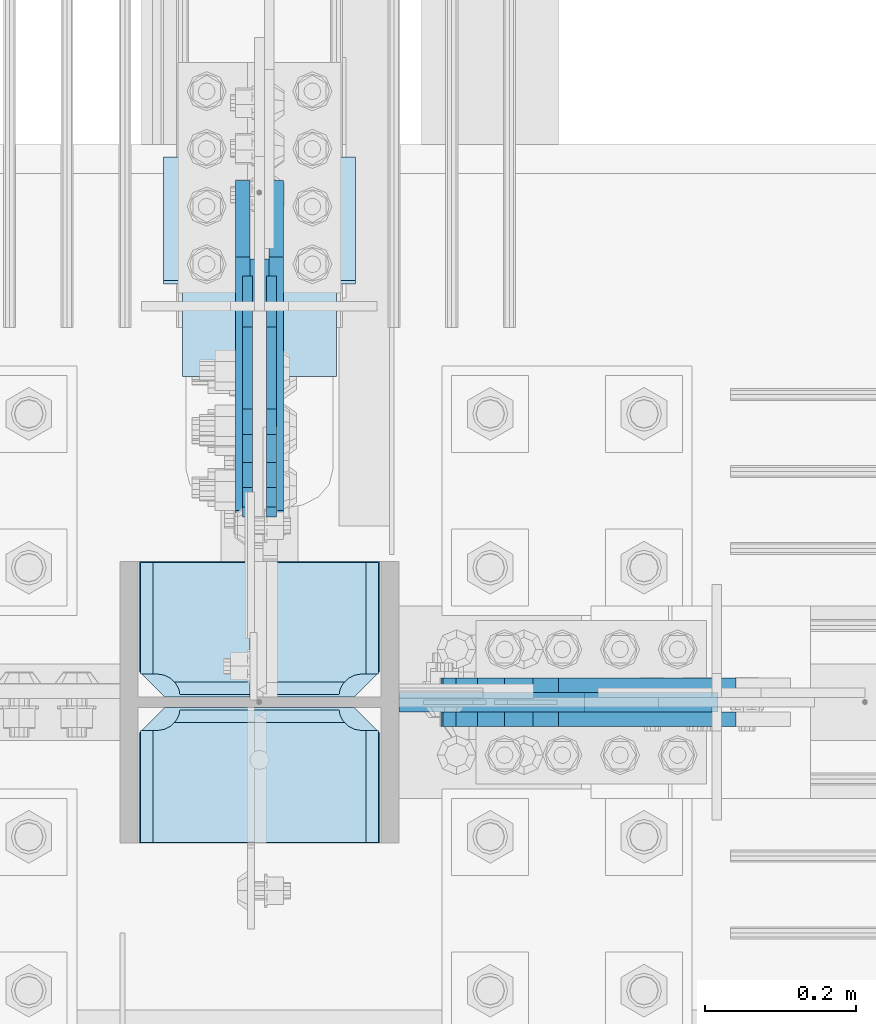
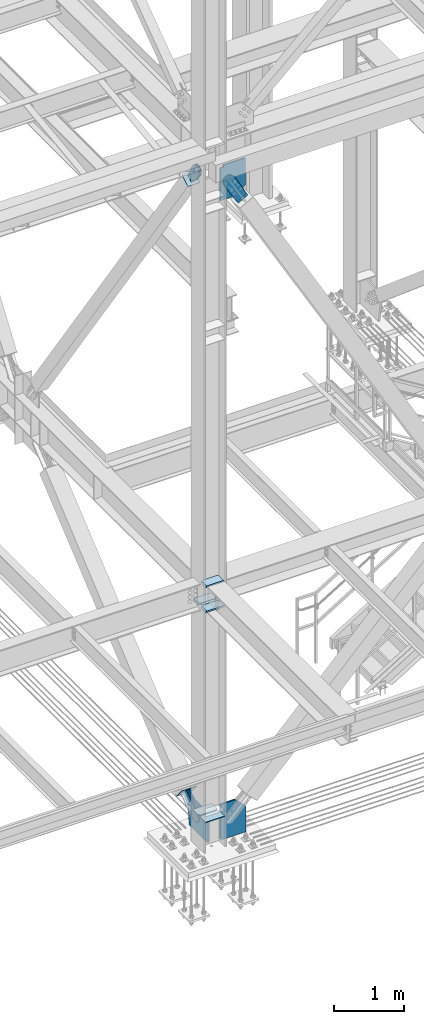
# One storey, part 3095 of 3843: 16 plates, 9 elements without a shape of their own.
"""IFC2X3 building model written with IfcOpenShell, lengths in millimetres."""

from ifc_helpers import new_model, si_unit, frame, origin_with_axes, place, context, subcontext, project, spatial, faceted_brep, material, type_object, element, aggregate, save


model = new_model("IFC2X3")

# Units and contexts
model_context = context("Model", 3, precision=1e-05, world=origin_with_axes())
body_context = subcontext(model_context, "Body", "Model", "MODEL_VIEW")
ifc_project = project(units=[si_unit("LENGTHUNIT", "METRE", prefix="MILLI"), si_unit("AREAUNIT", "SQUARE_METRE"), si_unit("VOLUMEUNIT", "CUBIC_METRE"), si_unit("MASSUNIT", "GRAM", prefix="KILO"), si_unit("TIMEUNIT", "SECOND"), si_unit("PLANEANGLEUNIT", "RADIAN"), si_unit("SOLIDANGLEUNIT", "STERADIAN"), si_unit("THERMODYNAMICTEMPERATUREUNIT", "DEGREE_CELSIUS"), si_unit("LUMINOUSINTENSITYUNIT", "LUMEN")], contexts=[model_context])

# Site, building, storey
site_placement = place(None, origin_with_axes())
site = spatial("IfcSite", under=ifc_project, at=site_placement, CompositionType="ELEMENT")
building_placement = place(site_placement, origin_with_axes())
building = spatial("IfcBuilding", under=site, at=building_placement, Name="Undefined", CompositionType="ELEMENT")
storey_placement = place(building_placement, origin_with_axes())
storey = spatial("IfcBuildingStorey", under=building, at=storey_placement, Name="Undefined", CompositionType="ELEMENT", Elevation=0.0)

# Assembly, plates
assembly_1_placement = place(storey_placement, origin_with_axes())
assembly_1 = element("IfcElementAssembly", 1, at=assembly_1_placement, inside=storey, Name="COLUMN", AssemblyPlace="NOTDEFINED", PredefinedType="RIGID_FRAME")
ifc_material_1 = material(Name="STEEL/A572-50")
plate_type_1 = type_object("IfcPlateType", PredefinedType="NOTDEFINED")
plate_1_placement = place(assembly_1_placement, frame((77171.55, 15005.84375, 30682.5348166373), z_axis=(0.0, 1.0, 0.0), x_axis=(-1.0, 0.0, 0.0)))
plate_1 = element("IfcPlate", 2, at=plate_1_placement, type_object=plate_type_1, material=ifc_material_1, Name="CB_COL", context=body_context, shape_type="Brep", body=[
    faceted_brep([(0.0, -6.34999999999854, 33.3375015258789), (0.0, -6.34999999999854, 178.59375), (0.0, 6.34999999999854, 178.59375), (0.0, 6.34999999999854, 33.3375015258789), (317.499999999985, -6.34999999999854, 178.59375), (317.499999999985, 6.34999999999854, 178.59375), (317.499999999985, -6.34999999999854, 33.3375015258789), (317.499999999985, 6.34999999999854, 33.3375015258789), (284.162498474107, -6.34999999999854, 0.0), (284.162498474107, 6.34999999999854, 0.0), (33.3375015258789, -6.34999999999854, 0.0), (33.3375015258789, 6.34999999999854, 0.0)], [[[0, 1, 2, 3]], [[1, 4, 5, 2]], [[4, 6, 7, 5]], [[6, 8, 9, 7]], [[8, 10, 11, 9]], [[10, 0, 3, 11]], [[5, 7, 9, 11, 3, 2]], [[10, 8, 6, 4, 1, 0]]]),
])
plate_2_placement = place(assembly_1_placement, frame((77171.55, 14991.55625, 30682.5348166373), z_axis=(0.0, -1.0, 0.0), x_axis=(-1.0, 0.0, 0.0)))
plate_2 = element("IfcPlate", 3, at=plate_2_placement, type_object=plate_type_1, material=ifc_material_1, Name="CB_COL", context=body_context, shape_type="Brep", body=[
    faceted_brep([(0.0, -6.34999999999854, 33.3375015258789), (0.0, -6.34999999999854, 178.59375), (0.0, 6.34999999999854, 178.59375), (0.0, 6.34999999999854, 33.3375015258789), (317.499999999985, -6.34999999999854, 178.59375), (317.499999999985, 6.34999999999854, 178.59375), (317.499999999985, -6.34999999999854, 33.3375015258789), (317.499999999985, 6.34999999999854, 33.3375015258789), (284.162498474107, -6.34999999999854, 0.0), (284.162498474107, 6.34999999999854, 0.0), (33.3375015258789, -6.34999999999854, 0.0), (33.3375015258789, 6.34999999999854, 0.0)], [[[0, 1, 2, 3]], [[1, 4, 5, 2]], [[4, 6, 7, 5]], [[6, 8, 9, 7]], [[8, 10, 11, 9]], [[10, 0, 3, 11]], [[5, 7, 9, 11, 3, 2]], [[10, 8, 6, 4, 1, 0]]]),
])
plate_type_2 = type_object("IfcPlateType", PredefinedType="NOTDEFINED")
plate_3_placement = place(assembly_1_placement, frame((77173.1375, 14991.55625, 34358.2625), z_axis=(-1.0, 0.0, 0.0), x_axis=(0.0, -1.0, 0.0)))
plate_3 = element("IfcPlate", 4, at=plate_3_placement, type_object=plate_type_2, material=ifc_material_1, Name="PLATE", context=body_context, shape_type="Brep", body=[
    faceted_brep([(17.7290728964945, 10.921700165738, 270.873024980028), (19.6722843348944, 14.2874999999985, 272.816236418425), (19.6722843348944, 14.2874999999985, 47.8587635815784), (17.7290728964945, 10.921700165738, 49.8019750199746), (9.32072521071495, -3.64224006636505, 54.0862421540805), (3.174499952318, -14.2874999999985, 55.0597086017369), (3.174499952318, -14.2874999999985, 265.615291398266), (9.32072521071677, -3.64224006636505, 266.588757845922), (177.799999999999, 14.2874999999985, 19.672284334898), (177.799999999999, -14.2874999999985, 3.17449995232164), (30.1625003814697, -14.2874999999985, 3.17449995232164), (30.1625003814697, 14.2874999999985, 19.672284334898), (30.1625003814697, 14.2874999999985, 301.001715665116), (30.1625003814697, -14.2874999999985, 317.499500047692), (177.800000000001, -14.2874999999985, 317.499500047692), (177.800000000001, 14.2874999999985, 301.001715665116), (9.32072521071677, -14.2874999999985, 266.588757845922), (17.7290728964945, -14.2874999999985, 270.873024980028), (24.4019754014498, -14.2874999999985, 277.545927484985), (24.4019754014498, 14.2874999999985, 277.545927484985), (28.6862425355521, -14.2874999999985, 285.954275170763), (28.6862425355521, 14.2874999999985, 285.954275170763), (30.1625003814697, -14.2874999999985, 295.275000381473), (30.1625003814697, 14.2874999999985, 295.275000381473), (30.1625003814697, -14.2874999999985, 25.3999996185303), (30.1625003814697, 14.2874999999985, 25.3999996185303), (28.6862425355503, -14.2874999999985, 34.7207248292398), (28.6862425355503, 14.2874999999985, 34.7207248292398), (24.401975401448, -14.2874999999985, 43.1290725150175), (24.401975401448, 14.2874999999985, 43.1290725150175), (17.7290728964945, -14.2874999999985, 49.8019750199746), (9.32072521071677, -14.2874999999985, 54.0862421540805)], [[[0, 1, 2, 3, 4, 5, 6, 7]], [[8, 9, 10, 11]], [[12, 13, 14, 15]], [[16, 7, 6]], [[16, 17, 0, 7]], [[17, 18, 19, 1, 0]], [[18, 20, 21, 19]], [[20, 22, 23, 21]], [[23, 22, 13, 12]], [[15, 14, 9, 8]], [[24, 25, 11, 10]], [[24, 26, 27, 25]], [[26, 28, 29, 27]], [[29, 28, 30, 3, 2]], [[30, 31, 4, 3]], [[31, 5, 4]], [[19, 21, 23, 12, 15, 8, 11, 25, 27, 29, 2, 1]], [[31, 30, 28, 26, 24, 10, 9, 14, 13, 22, 20, 18, 17, 16, 6, 5]]]),
])
plate_4_placement = place(assembly_1_placement, frame((77173.1375, 14991.55625, 34796.4125), z_axis=(-1.0, 0.0, 0.0), x_axis=(0.0, -1.0, 0.0)))
plate_4 = element("IfcPlate", 5, at=plate_4_placement, type_object=plate_type_2, material=ifc_material_1, Name="PLATE", context=body_context, shape_type="Brep", body=[
    faceted_brep([(17.7290728964945, 10.921700165738, 270.873024980028), (19.6722843348944, 14.2874999999985, 272.816236418425), (19.6722843348944, 14.2874999999985, 47.8587635815784), (17.7290728964945, 10.921700165738, 49.8019750199746), (9.32072521071495, -3.64224006636505, 54.0862421540805), (3.174499952318, -14.2874999999985, 55.0597086017369), (3.174499952318, -14.2874999999985, 265.615291398266), (9.32072521071677, -3.64224006636505, 266.588757845922), (177.799999999999, 14.2874999999985, 19.672284334898), (177.799999999999, -14.2874999999985, 3.17449995232164), (30.1625003814697, -14.2874999999985, 3.17449995232164), (30.1625003814697, 14.2874999999985, 19.672284334898), (30.1625003814697, 14.2874999999985, 301.001715665116), (30.1625003814697, -14.2874999999985, 317.499500047692), (177.800000000001, -14.2874999999985, 317.499500047692), (177.800000000001, 14.2874999999985, 301.001715665116), (9.32072521071677, -14.2874999999985, 266.588757845922), (17.7290728964945, -14.2874999999985, 270.873024980028), (24.4019754014498, -14.2874999999985, 277.545927484985), (24.4019754014498, 14.2874999999985, 277.545927484985), (28.6862425355521, -14.2874999999985, 285.954275170763), (28.6862425355521, 14.2874999999985, 285.954275170763), (30.1625003814697, -14.2874999999985, 295.275000381473), (30.1625003814697, 14.2874999999985, 295.275000381473), (30.1625003814697, -14.2874999999985, 25.3999996185303), (30.1625003814697, 14.2874999999985, 25.3999996185303), (28.6862425355503, -14.2874999999985, 34.7207248292398), (28.6862425355503, 14.2874999999985, 34.7207248292398), (24.401975401448, -14.2874999999985, 43.1290725150175), (24.401975401448, 14.2874999999985, 43.1290725150175), (17.7290728964945, -14.2874999999985, 49.8019750199746), (9.32072521071677, -14.2874999999985, 54.0862421540805)], [[[0, 1, 2, 3, 4, 5, 6, 7]], [[8, 9, 10, 11]], [[12, 13, 14, 15]], [[16, 7, 6]], [[16, 17, 0, 7]], [[17, 18, 19, 1, 0]], [[18, 20, 21, 19]], [[20, 22, 23, 21]], [[23, 22, 13, 12]], [[15, 14, 9, 8]], [[24, 25, 11, 10]], [[24, 26, 27, 25]], [[26, 28, 29, 27]], [[29, 28, 30, 3, 2]], [[30, 31, 4, 3]], [[31, 5, 4]], [[19, 21, 23, 12, 15, 8, 11, 25, 27, 29, 2, 1]], [[31, 30, 28, 26, 24, 10, 9, 14, 13, 22, 20, 18, 17, 16, 6, 5]]]),
])
plate_5_placement = place(assembly_1_placement, frame((77173.1375, 15183.64375, 34358.2625), z_axis=(-1.0, 0.0, 0.0), x_axis=(0.0, -1.0, 0.0)))
plate_5 = element("IfcPlate", 6, at=plate_5_placement, type_object=plate_type_2, material=ifc_material_1, Name="PLATE", context=body_context, shape_type="Brep", body=[
    faceted_brep([(160.070927103507, 10.9209519416981, 49.8019750199746), (158.127215665108, 14.2874999999985, 47.8582635815837), (158.127215665108, 14.2874999999985, 272.816736418419), (160.070927103507, 10.9209519416981, 270.873024980028), (168.479274789286, -3.64247862514458, 266.588757845922), (174.625000047685, -14.2874999999985, 265.615370590487), (174.625000047685, -14.2874999999985, 55.0596294095158), (168.479274789286, -3.64247862514458, 54.0862421540805), (147.637499618531, 14.2874999999985, 19.672284334898), (147.637499618531, -14.2874999999985, 3.17449995232164), (0.0, -14.2874999999985, 3.17449995232164), (0.0, 14.2874999999985, 19.672284334898), (0.0, 14.2874999999985, 301.001715665116), (0.0, -14.2874999999985, 317.499500047692), (147.637499618531, -14.2874999999985, 317.499500047692), (147.637499618531, 14.2874999999985, 301.001715665116), (147.637499618531, -14.2874999999985, 295.275000381473), (147.637499618531, 14.2874999999985, 295.275000381473), (149.113757464449, -14.2874999999985, 285.954275170763), (149.113757464449, 14.2874999999985, 285.954275170763), (153.398024598551, -14.2874999999985, 277.545927484985), (153.398024598551, 14.2874999999985, 277.545927484985), (160.070927103507, -14.2874999999985, 270.873024980028), (168.479274789286, -14.2874999999985, 266.588757845922), (168.479274789286, -14.2874999999985, 54.0862421540805), (160.070927103507, -14.2874999999985, 49.8019750199746), (153.398024598551, -14.2874999999985, 43.1290725150175), (153.398024598551, 14.2874999999985, 43.1290725150175), (149.113757464449, -14.2874999999985, 34.7207248292398), (149.113757464449, 14.2874999999985, 34.7207248292398), (147.637499618531, -14.2874999999985, 25.3999996185303), (147.637499618531, 14.2874999999985, 25.3999996185303)], [[[0, 1, 2, 3, 4, 5, 6, 7]], [[8, 9, 10, 11]], [[12, 13, 14, 15]], [[13, 12, 11, 10]], [[16, 17, 15, 14]], [[16, 18, 19, 17]], [[18, 20, 21, 19]], [[21, 20, 22, 3, 2]], [[22, 23, 4, 3]], [[23, 5, 4]], [[24, 7, 6]], [[24, 25, 0, 7]], [[25, 26, 27, 1, 0]], [[26, 28, 29, 27]], [[28, 30, 31, 29]], [[31, 30, 9, 8]], [[27, 29, 31, 8, 11, 12, 15, 17, 19, 21, 2, 1]], [[9, 30, 28, 26, 25, 24, 6, 5, 23, 22, 20, 18, 16, 14, 13, 10]]]),
])

# Assembly, plate
assembly_2_placement = place(storey_placement, origin_with_axes())
assembly_2 = element("IfcElementAssembly", 7, at=assembly_2_placement, inside=storey, Name="Plate", AssemblyPlace="NOTDEFINED", PredefinedType="RIGID_FRAME")
ifc_material_2 = material(Name="STEEL/A36")
plate_type_3 = type_object("IfcPlateType", PredefinedType="NOTDEFINED")
plate_6_placement = place(assembly_2_placement, frame((76911.2, 15430.7575143655, 41399.4204475295), z_axis=(0.0, 0.820514786824002, 0.571625300877387), x_axis=(1.0, 0.0, 0.0)))
plate_6 = element("IfcPlate", 8, at=plate_6_placement, type_object=plate_type_3, material=ifc_material_2, Name="Plate", context=body_context, shape_type="Brep", body=[
    faceted_brep([(0.0, -3.17499999999927, 0.0), (0.0, -3.17500000043947, 203.200000001736), (0.0, 3.1749999995518, 203.200000001743), (0.0, 3.17499999999927, 0.0), (203.200000000012, -3.17500000043947, 203.200000001736), (203.200000000012, 3.1749999995518, 203.200000001743), (203.199996948242, -3.17499999999927, 0.0), (203.199996948242, 3.17499999999927, 0.0)], [[[0, 1, 2, 3]], [[1, 4, 5, 2]], [[4, 6, 7, 5]], [[6, 0, 3, 7]], [[5, 7, 3, 2]], [[6, 4, 1, 0]]]),
])
aggregate(assembly_2, [plate_6])

assembly_3_placement = place(storey_placement, origin_with_axes())
assembly_3 = element("IfcElementAssembly", 9, at=assembly_3_placement, inside=storey, AssemblyPlace="NOTDEFINED", PredefinedType="RIGID_FRAME")
plate_type_4 = type_object("IfcPlateType", PredefinedType="NOTDEFINED")
plate_7_placement = place(assembly_3_placement, frame((76990.575, 15634.6095446843, 30577.0414235062), z_axis=(0.0, -0.640500588011717, 0.767957679014049), x_axis=(0.0, 0.767957679014049, 0.640500588011717)))
plate_7 = element("IfcPlate", 10, at=plate_7_placement, type_object=plate_type_4, material=ifc_material_2, context=body_context, shape_type="Brep", body=[
    faceted_brep([(0.0, -9.52500000000146, 0.0), (-101.599999999169, -9.52499999999418, -17.6403935107228), (-101.599999999169, 9.52499999999418, -17.6403935107228), (0.0, 9.52500000000146, 0.0), (-320.279297659972, -9.52499999999418, -17.640393512258), (-320.279297659972, 9.52499999999418, -17.640393512258), (-357.3374051259, -9.52499999999418, -10.2690776257878), (-357.3374051259, 9.52499999999418, -10.2690776257878), (-388.753751662653, -9.52499999999418, 10.7226540115298), (-388.753751662653, 9.52499999999418, 10.7226540115298), (-409.745483299826, -9.52499999999418, 42.1390005483918), (-409.745483299826, 9.52499999999418, 42.1390005483918), (-417.116799186137, -9.52499999999418, 79.1971049608474), (-417.116799186137, 9.52499999999418, 79.1971049608474), (-409.745483299252, -9.52499999999418, 116.255212426157), (-409.745483299252, 9.52499999999418, 116.255212426157), (-388.75375166202, -9.52499999999418, 147.671558962465), (-388.75375166202, 9.52499999999418, 147.671558962465), (-357.33740512564, -9.52499999999418, 168.663290599579), (-357.33740512564, 9.52499999999418, 168.663290599579), (-320.279299186061, -9.52499999999418, 176.034606486319), (-320.279299186061, 9.52499999999418, 176.034606486319), (-101.599999997048, -9.52499999999418, 176.034606487883), (-101.599999997048, 9.52499999999418, 176.034606487883), (1.71894498635083e-09, -9.52499999999418, 158.39421297863), (1.71894498635083e-09, 9.52499999999418, 158.39421297863), (69.8500000010408, -9.52499999999418, 158.394212979103), (69.8500000010408, 9.52499999999418, 158.394212979103), (69.8499999979995, -9.52499999999418, -4.00177668780088e-10), (69.8499999979995, 9.52499999999418, -4.00177668780088e-10)], [[[0, 1, 2, 3]], [[1, 4, 5, 2]], [[4, 6, 7, 5]], [[6, 8, 9, 7]], [[8, 10, 11, 9]], [[10, 12, 13, 11]], [[12, 14, 15, 13]], [[14, 16, 17, 15]], [[16, 18, 19, 17]], [[18, 20, 21, 19]], [[20, 22, 23, 21]], [[22, 24, 25, 23]], [[24, 26, 27, 25]], [[26, 28, 29, 27]], [[28, 0, 3, 29]], [[5, 7, 9, 11, 13, 15, 17, 19, 21, 23, 25, 27, 29, 3, 2]], [[28, 26, 24, 22, 20, 18, 16, 14, 12, 10, 8, 6, 4, 1, 0]]]),
])
aggregate(assembly_3, [plate_7])

assembly_4_placement = place(storey_placement, origin_with_axes())
assembly_4 = element("IfcElementAssembly", 11, at=assembly_4_placement, inside=storey, AssemblyPlace="NOTDEFINED", PredefinedType="RIGID_FRAME")
plate_8_placement = place(assembly_4_placement, frame((77035.025, 15634.6095446843, 30577.0414235062), z_axis=(0.0, -0.640500588011717, 0.767957679014049), x_axis=(0.0, 0.767957679014049, 0.640500588011717)))
plate_8 = element("IfcPlate", 12, at=plate_8_placement, type_object=plate_type_4, material=ifc_material_2, context=body_context, shape_type="Brep", body=[
    faceted_brep([(0.0, -9.52500000000146, 0.0), (-101.599999999169, -9.52499999999418, -17.6403935107228), (-101.599999999169, 9.52499999999418, -17.6403935107228), (0.0, 9.52500000000146, 0.0), (-320.279297659972, -9.52499999999418, -17.640393512258), (-320.279297659972, 9.52499999999418, -17.640393512258), (-357.3374051259, -9.52499999999418, -10.2690776257878), (-357.3374051259, 9.52499999999418, -10.2690776257878), (-388.753751662653, -9.52499999999418, 10.7226540115298), (-388.753751662653, 9.52499999999418, 10.7226540115298), (-409.745483299826, -9.52499999999418, 42.1390005483918), (-409.745483299826, 9.52499999999418, 42.1390005483918), (-417.116799186137, -9.52499999999418, 79.1971049608474), (-417.116799186137, 9.52499999999418, 79.1971049608474), (-409.745483299252, -9.52499999999418, 116.255212426157), (-409.745483299252, 9.52499999999418, 116.255212426157), (-388.75375166202, -9.52499999999418, 147.671558962465), (-388.75375166202, 9.52499999999418, 147.671558962465), (-357.33740512564, -9.52499999999418, 168.663290599579), (-357.33740512564, 9.52499999999418, 168.663290599579), (-320.279299186061, -9.52499999999418, 176.034606486319), (-320.279299186061, 9.52499999999418, 176.034606486319), (-101.599999997048, -9.52499999999418, 176.034606487883), (-101.599999997048, 9.52499999999418, 176.034606487883), (1.71894498635083e-09, -9.52499999999418, 158.39421297863), (1.71894498635083e-09, 9.52499999999418, 158.39421297863), (69.8500000010408, -9.52499999999418, 158.394212979103), (69.8500000010408, 9.52499999999418, 158.394212979103), (69.8499999979995, -9.52499999999418, -4.00177668780088e-10), (69.8499999979995, 9.52499999999418, -4.00177668780088e-10)], [[[0, 1, 2, 3]], [[1, 4, 5, 2]], [[4, 6, 7, 5]], [[6, 8, 9, 7]], [[8, 10, 11, 9]], [[10, 12, 13, 11]], [[12, 14, 15, 13]], [[14, 16, 17, 15]], [[16, 18, 19, 17]], [[18, 20, 21, 19]], [[20, 22, 23, 21]], [[22, 24, 25, 23]], [[24, 26, 27, 25]], [[26, 28, 29, 27]], [[28, 0, 3, 29]], [[5, 7, 9, 11, 13, 15, 17, 19, 21, 23, 25, 27, 29, 3, 2]], [[28, 26, 24, 22, 20, 18, 16, 14, 12, 10, 8, 6, 4, 1, 0]]]),
])
aggregate(assembly_4, [plate_8])

assembly_5_placement = place(storey_placement, origin_with_axes())
assembly_5 = element("IfcElementAssembly", 13, at=assembly_5_placement, inside=storey, AssemblyPlace="NOTDEFINED", PredefinedType="RIGID_FRAME")
plate_9_placement = place(assembly_5_placement, frame((77607.6138818287, 15020.925, 41336.5129775429), z_axis=(-0.868467373134184, 0.0, -0.495746328076577), x_axis=(0.495746328076598, 0.0, -0.868467373134173)))
plate_9 = element("IfcPlate", 14, at=plate_9_placement, type_object=plate_type_4, material=ifc_material_2, context=body_context, shape_type="Brep", body=[
    faceted_brep([(0.0, -9.52500000000146, 0.0), (-101.59999999866, -9.52499999999418, -7.01164927375794), (-101.59999999866, 9.52499999999418, -7.01164927375794), (0.0, 9.52500000000146, 0.0), (-364.729297655074, -9.52499999999418, -7.01164927444188), (-364.729297655074, 9.52499999999418, -7.01164927444188), (-401.787405121293, -9.52499999999418, 0.359666612348519), (-401.787405121293, 9.52499999999418, 0.359666612348519), (-433.203751657995, -9.52499999999418, 21.3513982502482), (-433.203751657995, 9.52499999999418, 21.3513982502482), (-454.195483294687, -9.52499999999418, 52.7677447877504), (-454.195483294687, 9.52499999999418, 52.7677447877504), (-461.566799180051, -9.52499999999418, 89.8258492000314), (-461.566799180051, 9.52499999999418, 89.8258492000314), (-454.195483292249, -9.52499999999418, 126.883956664562), (-454.195483292249, 9.52499999999418, 126.883956664562), (-433.203751654662, -9.52499999999418, 158.300303199998), (-433.203751654662, 9.52499999999418, 158.300303199998), (-401.787405118426, -9.52499999999418, 179.292034836384), (-401.787405118426, 9.52499999999418, 179.292034836384), (-364.729299177612, -9.52499999999418, 186.663350722738), (-364.729299177612, 9.52499999999418, 186.663350722738), (-101.5999999907, -9.52499999999418, 186.663350723451), (-101.5999999907, 9.52499999999418, 186.663350723451), (7.37782102078199e-09, -9.52499999999418, 179.651701450231), (7.37782102078199e-09, 9.52499999999418, 179.651701450231), (69.8500000062704, -9.52499999999418, 179.651701450392), (69.8500000062704, 9.52499999999418, 179.651701450392), (69.8499999979995, -9.52499999999418, -4.00177668780088e-10), (69.8499999979995, 9.52499999999418, -4.00177668780088e-10)], [[[0, 1, 2, 3]], [[1, 4, 5, 2]], [[4, 6, 7, 5]], [[6, 8, 9, 7]], [[8, 10, 11, 9]], [[10, 12, 13, 11]], [[12, 14, 15, 13]], [[14, 16, 17, 15]], [[16, 18, 19, 17]], [[18, 20, 21, 19]], [[20, 22, 23, 21]], [[22, 24, 25, 23]], [[24, 26, 27, 25]], [[26, 28, 29, 27]], [[28, 0, 3, 29]], [[5, 7, 9, 11, 13, 15, 17, 19, 21, 23, 25, 27, 29, 3, 2]], [[28, 26, 24, 22, 20, 18, 16, 14, 12, 10, 8, 6, 4, 1, 0]]]),
])
aggregate(assembly_5, [plate_9])

assembly_6_placement = place(storey_placement, origin_with_axes())
assembly_6 = element("IfcElementAssembly", 15, at=assembly_6_placement, inside=storey, AssemblyPlace="NOTDEFINED", PredefinedType="RIGID_FRAME")
plate_10_placement = place(assembly_6_placement, frame((77607.6138818287, 14976.475, 41336.5129775429), z_axis=(-0.868467373134184, 0.0, -0.495746328076577), x_axis=(0.495746328076598, 0.0, -0.868467373134173)))
plate_10 = element("IfcPlate", 16, at=plate_10_placement, type_object=plate_type_4, material=ifc_material_2, context=body_context, shape_type="Brep", body=[
    faceted_brep([(0.0, -9.52500000000146, 0.0), (-101.59999999866, -9.52499999999418, -7.01164927375794), (-101.59999999866, 9.52499999999418, -7.01164927375794), (0.0, 9.52500000000146, 0.0), (-364.729297655074, -9.52499999999418, -7.01164927444188), (-364.729297655074, 9.52499999999418, -7.01164927444188), (-401.787405121293, -9.52499999999418, 0.359666612348519), (-401.787405121293, 9.52499999999418, 0.359666612348519), (-433.203751657995, -9.52499999999418, 21.3513982502482), (-433.203751657995, 9.52499999999418, 21.3513982502482), (-454.195483294687, -9.52499999999418, 52.7677447877504), (-454.195483294687, 9.52499999999418, 52.7677447877504), (-461.566799180051, -9.52499999999418, 89.8258492000314), (-461.566799180051, 9.52499999999418, 89.8258492000314), (-454.195483292249, -9.52499999999418, 126.883956664562), (-454.195483292249, 9.52499999999418, 126.883956664562), (-433.203751654662, -9.52499999999418, 158.300303199998), (-433.203751654662, 9.52499999999418, 158.300303199998), (-401.787405118426, -9.52499999999418, 179.292034836384), (-401.787405118426, 9.52499999999418, 179.292034836384), (-364.729299177612, -9.52499999999418, 186.663350722738), (-364.729299177612, 9.52499999999418, 186.663350722738), (-101.5999999907, -9.52499999999418, 186.663350723451), (-101.5999999907, 9.52499999999418, 186.663350723451), (7.37782102078199e-09, -9.52499999999418, 179.651701450231), (7.37782102078199e-09, 9.52499999999418, 179.651701450231), (69.8500000062704, -9.52499999999418, 179.651701450392), (69.8500000062704, 9.52499999999418, 179.651701450392), (69.8499999979995, -9.52499999999418, -4.00177668780088e-10), (69.8499999979995, 9.52499999999418, -4.00177668780088e-10)], [[[0, 1, 2, 3]], [[1, 4, 5, 2]], [[4, 6, 7, 5]], [[6, 8, 9, 7]], [[8, 10, 11, 9]], [[10, 12, 13, 11]], [[12, 14, 15, 13]], [[14, 16, 17, 15]], [[16, 18, 19, 17]], [[18, 20, 21, 19]], [[20, 22, 23, 21]], [[22, 24, 25, 23]], [[24, 26, 27, 25]], [[26, 28, 29, 27]], [[28, 0, 3, 29]], [[5, 7, 9, 11, 13, 15, 17, 19, 21, 23, 25, 27, 29, 3, 2]], [[28, 26, 24, 22, 20, 18, 16, 14, 12, 10, 8, 6, 4, 1, 0]]]),
])
aggregate(assembly_6, [plate_10])

assembly_7_placement = place(storey_placement, origin_with_axes())
assembly_7 = element("IfcElementAssembly", 17, at=assembly_7_placement, inside=storey, Name="Plate", AssemblyPlace="NOTDEFINED", PredefinedType="RIGID_FRAME")
plate_type_5 = type_object("IfcPlateType", PredefinedType="NOTDEFINED")
plate_11_placement = place(assembly_7_placement, frame((77139.8, 15716.4309042892, 30583.0362011159), z_axis=(0.0, -0.640500588011717, 0.767957679014049), x_axis=(-1.0, 0.0, 0.0)))
plate_11 = element("IfcPlate", 18, at=plate_11_placement, type_object=plate_type_5, material=ifc_material_2, Name="Plate", context=body_context, shape_type="Brep", body=[
    faceted_brep([(0.0, -3.17499999999927, 0.0), (0.0, -3.17499999965185, 254.000000005151), (0.0, 3.17500000035216, 254.000000005166), (0.0, 3.17499999999927, 0.0), (254.0, -3.17499999965185, 254.000000005151), (254.0, 3.17500000035216, 254.000000005166), (254.0, -3.17500000000291, 0.0), (254.0, 3.17499999999927, 1.45519152283669e-11)], [[[0, 1, 2, 3]], [[1, 4, 5, 2]], [[4, 6, 7, 5]], [[6, 0, 3, 7]], [[5, 7, 3, 2]], [[6, 4, 1, 0]]]),
])
aggregate(assembly_7, [plate_11])

assembly_8_placement = place(storey_placement, origin_with_axes())
assembly_8 = element("IfcElementAssembly", 19, at=assembly_8_placement, inside=storey, AssemblyPlace="NOTDEFINED", PredefinedType="RIGID_FRAME")
plate_type_6 = type_object("IfcPlateType", PredefinedType="NOTDEFINED")
plate_12_placement = place(assembly_8_placement, frame((76996.925, 15522.0333973985, 41544.2692741034), z_axis=(0.0, -0.820514786824023, -0.571625300877357), x_axis=(0.0, 0.571625300877389, -0.820514786824)))
plate_12 = element("IfcPlate", 20, at=plate_12_placement, type_object=plate_type_6, material=ifc_material_2, context=body_context, shape_type="Brep", body=[
    faceted_brep([(0.0, -6.3499999046162, 0.0), (-101.600000000049, -6.35000000000582, -37.5700346004523), (-101.600000000049, 6.35000000000582, -37.5700346004523), (7.27595761418343e-12, 6.3499999046162, 0.0), (-245.369242325265, -6.35000000000582, -37.5700346003141), (-245.369242325265, 6.35000000000582, -37.5700346003141), (-281.212328726207, -6.35000000000582, -30.4404014297979), (-281.212328726207, 6.35000000000582, -30.4404014297979), (-311.59863014071, -6.35000000000582, -10.1369239383566), (-311.59863014071, 6.35000000000582, -10.1369239383566), (-331.902107630653, -6.35000000000582, 20.2493774772229), (-331.902107630653, 6.35000000000582, 20.2493774772229), (-339.031740799503, -6.35000000000582, 56.0924669294036), (-339.031740799503, 6.35000000000582, 56.0924669294036), (-331.902107628353, -6.35000000000582, 91.9355533280759), (-331.902107628353, 6.35000000000582, 91.9355533280759), (-311.598630138033, -6.35000000000582, 122.321854740563), (-311.598630138033, 6.35000000000582, 122.321854740563), (-281.212328724767, -6.35000000000582, 142.625332229603), (-281.212328724767, 6.35000000000582, 142.625332229603), (-245.369240796863, -6.35000000000582, 149.754965399145), (-245.369240796863, 6.35000000000582, 149.754965399145), (-101.599999991755, -6.35000000000582, 149.754965398992), (-101.599999991755, 6.35000000000582, 149.754965398992), (4.9622030928731e-09, -6.35000000000582, 112.184930798256), (4.9622030928731e-09, 6.35000000000582, 112.184930798256), (69.8500000038475, -6.35000000000582, 112.184930798168), (69.8500000038475, 6.35000000000582, 112.184930798168), (69.8499999985434, -6.35000000000582, -8.73114913702011e-11), (69.8499999985434, 6.35000000000582, -8.73114913702011e-11)], [[[0, 1, 2, 3]], [[1, 4, 5, 2]], [[4, 6, 7, 5]], [[6, 8, 9, 7]], [[8, 10, 11, 9]], [[10, 12, 13, 11]], [[12, 14, 15, 13]], [[14, 16, 17, 15]], [[16, 18, 19, 17]], [[18, 20, 21, 19]], [[20, 22, 23, 21]], [[22, 24, 25, 23]], [[24, 26, 27, 25]], [[26, 28, 29, 27]], [[28, 0, 3, 29]], [[5, 7, 9, 11, 13, 15, 17, 19, 21, 23, 25, 27, 29, 3, 2]], [[28, 26, 24, 22, 20, 18, 16, 14, 12, 10, 8, 6, 4, 1, 0]]]),
])
aggregate(assembly_8, [plate_12])

assembly_9_placement = place(storey_placement, origin_with_axes())
assembly_9 = element("IfcElementAssembly", 21, at=assembly_9_placement, inside=storey, AssemblyPlace="NOTDEFINED", PredefinedType="RIGID_FRAME")
plate_13_placement = place(assembly_9_placement, frame((77028.675, 15522.0333973985, 41544.2692741034), z_axis=(0.0, -0.820514786824023, -0.571625300877357), x_axis=(0.0, 0.571625300877389, -0.820514786824)))
plate_13 = element("IfcPlate", 22, at=plate_13_placement, type_object=plate_type_6, material=ifc_material_2, context=body_context, shape_type="Brep", body=[
    faceted_brep([(0.0, -6.3499999046162, 0.0), (-101.600000000049, -6.35000000000582, -37.5700346004523), (-101.600000000049, 6.35000000000582, -37.5700346004523), (7.27595761418343e-12, 6.3499999046162, 0.0), (-245.369242325265, -6.35000000000582, -37.5700346003141), (-245.369242325265, 6.35000000000582, -37.5700346003141), (-281.212328726207, -6.35000000000582, -30.4404014297979), (-281.212328726207, 6.35000000000582, -30.4404014297979), (-311.59863014071, -6.35000000000582, -10.1369239383566), (-311.59863014071, 6.35000000000582, -10.1369239383566), (-331.902107630653, -6.35000000000582, 20.2493774772229), (-331.902107630653, 6.35000000000582, 20.2493774772229), (-339.031740799503, -6.35000000000582, 56.0924669294036), (-339.031740799503, 6.35000000000582, 56.0924669294036), (-331.902107628353, -6.35000000000582, 91.9355533280759), (-331.902107628353, 6.35000000000582, 91.9355533280759), (-311.598630138033, -6.35000000000582, 122.321854740563), (-311.598630138033, 6.35000000000582, 122.321854740563), (-281.212328724767, -6.35000000000582, 142.625332229603), (-281.212328724767, 6.35000000000582, 142.625332229603), (-245.369240796863, -6.35000000000582, 149.754965399145), (-245.369240796863, 6.35000000000582, 149.754965399145), (-101.599999991755, -6.35000000000582, 149.754965398992), (-101.599999991755, 6.35000000000582, 149.754965398992), (4.9622030928731e-09, -6.35000000000582, 112.184930798256), (4.9622030928731e-09, 6.35000000000582, 112.184930798256), (69.8500000038475, -6.35000000000582, 112.184930798168), (69.8500000038475, 6.35000000000582, 112.184930798168), (69.8499999985434, -6.35000000000582, -8.73114913702011e-11), (69.8499999985434, 6.35000000000582, -8.73114913702011e-11)], [[[0, 1, 2, 3]], [[1, 4, 5, 2]], [[4, 6, 7, 5]], [[6, 8, 9, 7]], [[8, 10, 11, 9]], [[10, 12, 13, 11]], [[12, 14, 15, 13]], [[14, 16, 17, 15]], [[16, 18, 19, 17]], [[18, 20, 21, 19]], [[20, 22, 23, 21]], [[22, 24, 25, 23]], [[24, 26, 27, 25]], [[26, 28, 29, 27]], [[28, 0, 3, 29]], [[5, 7, 9, 11, 13, 15, 17, 19, 21, 23, 25, 27, 29, 3, 2]], [[28, 26, 24, 22, 20, 18, 16, 14, 12, 10, 8, 6, 4, 1, 0]]]),
])
aggregate(assembly_9, [plate_13])

# Plate
plate_type_7 = type_object("IfcPlateType", PredefinedType="NOTDEFINED")
plate_14_placement = place(assembly_1_placement, frame((77012.8, 15005.84375, 30149.8), z_axis=(0.0, 0.0, 1.0), x_axis=(0.0, 1.0, 0.0)))
plate_14 = element("IfcPlate", 23, at=plate_14_placement, type_object=plate_type_7, material=ifc_material_1, Name="CB", context=body_context, shape_type="Brep", body=[
    faceted_brep([(0.0, -12.6999999999971, 19.0499992370605), (0.0, -12.6999999999971, 507.334817400235), (0.0, 12.6999999999971, 507.334817400235), (0.0, 12.6999999999971, 19.0499992370605), (19.0499992370605, -12.6999999999971, 526.384816637295), (19.0499992370605, 12.6999999999971, 526.384816637295), (413.778164363473, -12.6999999999971, 526.384816637295), (413.778164363473, 12.6999999999971, 526.384816637295), (578.30869184796, -12.6999999999971, 329.113363060336), (578.30869184796, 12.6999999999971, 329.113363060336), (533.399999999998, -12.6999999999971, 0.0), (533.399999999998, 12.6999999999971, 0.0), (19.0500015258731, -12.6999999999971, -6.33008312433958e-10), (19.0500015258731, 12.6999999999971, 0.0)], [[[0, 1, 2, 3]], [[1, 4, 5, 2]], [[4, 6, 7, 5]], [[6, 8, 9, 7]], [[8, 10, 11, 9]], [[10, 12, 13, 11]], [[12, 0, 3, 13]], [[5, 7, 9, 11, 13, 3, 2]], [[12, 10, 8, 6, 4, 1, 0]]]),
])

plate_type_8 = type_object("IfcPlateType", PredefinedType="NOTDEFINED")
plate_15_placement = place(assembly_1_placement, frame((77196.95, 14998.7, 30149.8), z_axis=(0.0, 0.0, 1.0), x_axis=(1.0, 0.0, 0.0)))
plate_15 = element("IfcPlate", 24, at=plate_15_placement, type_object=plate_type_8, material=ifc_material_1, Name="CB", context=body_context, shape_type="Brep", body=[
    faceted_brep([(0.0, -12.6999999999971, 19.0499992370605), (0.0, -12.7000000000007, 622.191183947351), (0.0, 12.7000000000007, 622.191183947351), (0.0, 12.6999999999971, 19.0499992370605), (245.411000082924, -12.7000000000007, 622.191183947351), (245.411000082924, 12.7000000000007, 622.191183947351), (421.492821723063, -12.7000000000007, 452.593961939165), (421.492821723063, 12.7000000000007, 452.593961939165), (421.492821723063, -12.7000000000007, 0.0), (421.492821723063, 12.7000000000007, 0.0), (19.0500015258731, -12.6999999999971, -6.33008312433958e-10), (19.0500015258731, 12.6999999999971, 0.0)], [[[0, 1, 2, 3]], [[1, 4, 5, 2]], [[4, 6, 7, 5]], [[6, 8, 9, 7]], [[8, 10, 11, 9]], [[10, 0, 3, 11]], [[5, 7, 9, 11, 3, 2]], [[10, 8, 6, 4, 1, 0]]]),
])

plate_type_9 = type_object("IfcPlateType", PredefinedType="NOTDEFINED")
plate_16_placement = place(assembly_1_placement, frame((77610.7945147725, 14998.7, 42468.8), z_axis=(0.0, 0.0, -1.0), x_axis=(-1.0, 0.0, 0.0)))
plate_16 = element("IfcPlate", 25, at=plate_16_placement, type_object=plate_type_9, material=ifc_material_1, Name="CB", context=body_context, shape_type="Brep", body=[
    faceted_brep([(363.044514772759, -12.7000000000007, 542.925000000003), (363.044514772759, 12.7000000000007, 542.925000000003), (363.058643144774, 12.7000000000007, 568.310840325415), (363.058643144774, -12.7000000000007, 568.310840325415), (364.029432474606, 12.7000000000007, 573.173645169598), (364.029432474606, -12.7000000000007, 573.173645169598), (366.788386410219, 12.7000000000007, 577.294018460525), (366.788386410219, -12.7000000000007, 577.294018460525), (370.914891423294, 12.7000000000007, 580.043792860772), (370.914891423294, -12.7000000000007, 580.043792860772), (375.77984537094, 12.7000000000007, 581.003754298814), (375.77984537094, -12.7000000000007, 581.003754298814), (413.8657191495, -12.7000000000007, 580.940164643391), (413.844514772747, 12.7000000000007, 580.940182369952), (0.0, -12.7000000000007, 1013.4837255796), (0.0, 12.7000000000007, 1013.4837255796), (0.0, 12.7000000000007, 542.925000000003), (0.0, -12.7000000000007, 542.925000000003), (237.718561046975, -12.7000000000007, 1149.18036473991), (237.718561046975, 12.7000000000007, 1149.18036473991), (413.844514772747, -12.7000000000007, 1149.18036473991), (413.844514772747, 12.7000000000007, 1149.18036473991)], [[[0, 1, 2, 3]], [[3, 2, 4, 5]], [[5, 4, 6, 7]], [[7, 6, 8, 9]], [[9, 8, 10, 11]], [[12, 11, 10, 13]], [[14, 15, 16, 17]], [[14, 18, 19, 15]], [[18, 20, 21, 19]], [[21, 20, 12, 13]], [[8, 6, 4, 2, 1, 16, 15, 19, 21, 13, 10]], [[17, 16, 1, 0]], [[20, 18, 14, 17, 0, 3, 5, 7, 9, 11, 12]]]),
])

aggregate(assembly_1, [plate_3, plate_4, plate_1, plate_2, plate_14, plate_15, plate_16, plate_5])

save(model, "model.ifc")
